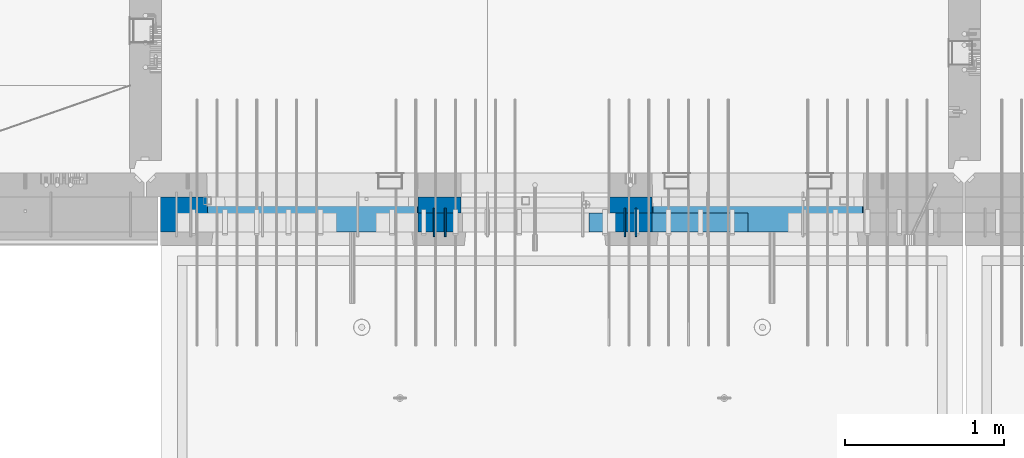
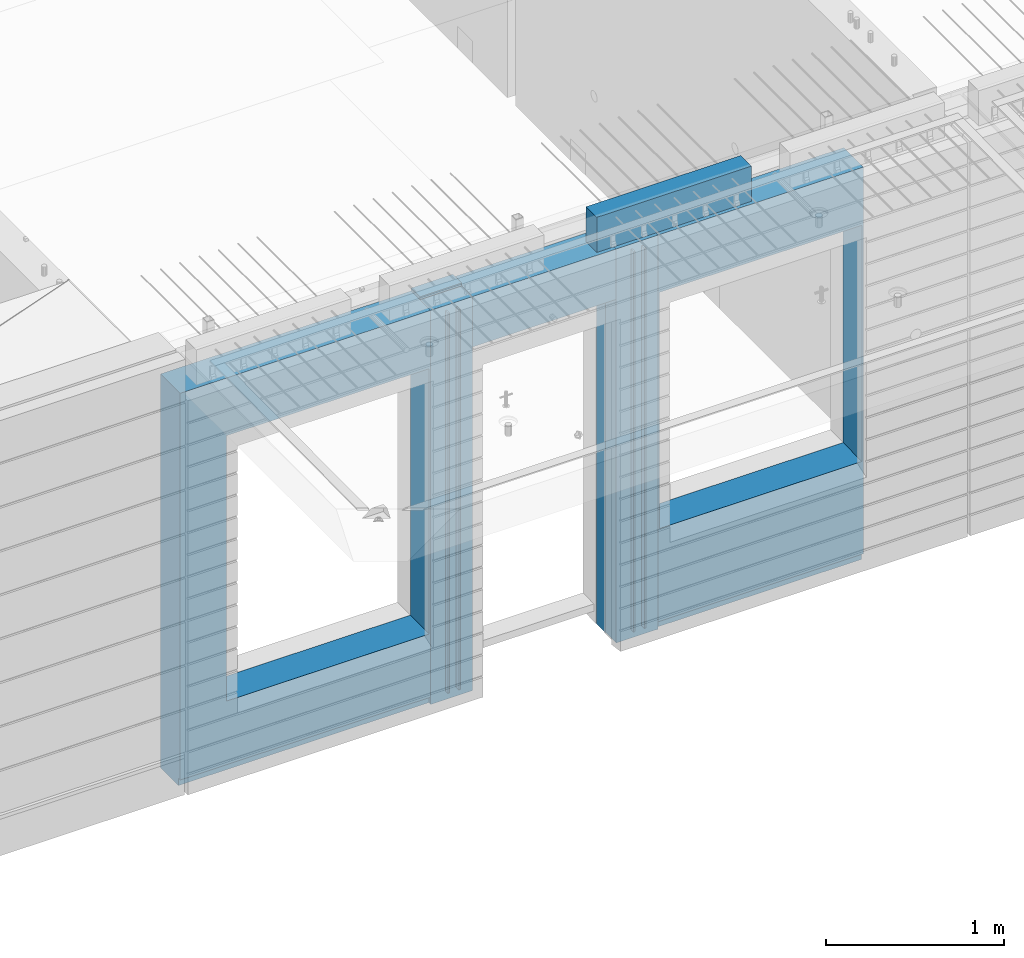
# One storey, part 230 of 350: 10 walls, 3 elements without a shape of their own.
"""IFC2X3 building model written with IfcOpenShell, lengths in millimetres."""

from ifc_helpers import new_model, si_unit, frame, origin_with_axes, place, context, subcontext, project, spatial, faceted_brep, material, type_object, element, aggregate, save


model = new_model("IFC2X3")

# Units and contexts
model_context = context("Model", 3, precision=1e-05, world=origin_with_axes())
body_context = subcontext(model_context, "Body", "Model", "MODEL_VIEW")
ifc_project = project(units=[si_unit("LENGTHUNIT", "METRE", prefix="MILLI"), si_unit("AREAUNIT", "SQUARE_METRE"), si_unit("VOLUMEUNIT", "CUBIC_METRE"), si_unit("MASSUNIT", "GRAM", prefix="KILO"), si_unit("TIMEUNIT", "SECOND"), si_unit("PLANEANGLEUNIT", "RADIAN"), si_unit("SOLIDANGLEUNIT", "STERADIAN"), si_unit("THERMODYNAMICTEMPERATUREUNIT", "DEGREE_CELSIUS"), si_unit("LUMINOUSINTENSITYUNIT", "LUMEN")], contexts=[model_context])

# Site, building, storey
site_placement = place(None, origin_with_axes())
site = spatial("IfcSite", under=ifc_project, at=site_placement, CompositionType="ELEMENT")
building_placement = place(site_placement, origin_with_axes())
building = spatial("IfcBuilding", under=site, at=building_placement, CompositionType="ELEMENT")
storey_placement = place(building_placement, origin_with_axes())
storey = spatial("IfcBuildingStorey", under=building, at=storey_placement, Name="2", CompositionType="ELEMENT", Elevation=0.0)

# Assembly, walls
assembly_1_placement = place(storey_placement, origin_with_axes())
assembly_1 = element("IfcElementAssembly", 1, at=assembly_1_placement, inside=storey, AssemblyPlace="NOTDEFINED", PredefinedType="REINFORCEMENT_UNIT")
ifc_material_1 = material(Name="Undefined")
wall_type_1 = type_object("IfcWallType", PredefinedType="NOTDEFINED")
wall_1_placement = place(assembly_1_placement, frame((18475.0, 7780.0, 86115.0), z_axis=(0.0, 0.0, 1.0), x_axis=(0.0, -1.0, 0.0)))
wall_1 = element("IfcWall", 2, at=wall_1_placement, type_object=wall_type_1, material=ifc_material_1, Name="(PD)", context=body_context, shape_type="Brep", body=[
    faceted_brep([(0.0, 5.0, -1300.0), (0.0, 5.0, 1300.0), (180.0, 5.0, 1300.0), (180.0, 5.0, -1300.0), (0.0, -5.0, 1300.0), (180.0, -5.0, 1300.0), (0.0, -5.0, -1300.0), (180.0, -5.0, -1300.0)], [[[0, 1, 2, 3]], [[1, 4, 5, 2]], [[4, 6, 7, 5]], [[6, 0, 3, 7]], [[5, 7, 3, 2]], [[6, 4, 1, 0]]]),
])
wall_2_placement = place(assembly_1_placement, frame((18545.0, 7780.0, 86115.0), z_axis=(0.0, 0.0, 1.0), x_axis=(0.0, -1.0, 0.0)))
wall_2 = element("IfcWall", 3, at=wall_2_placement, type_object=wall_type_1, material=ifc_material_1, Name="(PD)", context=body_context, shape_type="Brep", body=[
    faceted_brep([(0.0, 5.0, -1300.0), (0.0, 5.0, 1300.0), (180.0, 5.0, 1300.0), (180.0, 5.0, -1300.0), (0.0, -5.0, 1300.0), (180.0, -5.0, 1300.0), (0.0, -5.0, -1300.0), (180.0, -5.0, -1300.0)], [[[0, 1, 2, 3]], [[1, 4, 5, 2]], [[4, 6, 7, 5]], [[6, 0, 3, 7]], [[5, 7, 3, 2]], [[6, 4, 1, 0]]]),
])
wall_3_placement = place(assembly_1_placement, frame((19675.0, 7779.99999999997, 86115.0), z_axis=(0.0, 0.0, 1.0), x_axis=(0.0, -1.0, 0.0)))
wall_3 = element("IfcWall", 4, at=wall_3_placement, type_object=wall_type_1, material=ifc_material_1, Name="(PD)", context=body_context, shape_type="Brep", body=[
    faceted_brep([(0.0, 5.0, -1300.0), (0.0, 5.0, 1300.0), (180.0, 5.0, 1300.0), (180.0, 5.0, -1300.0), (0.0, -5.0, 1300.0), (180.0, -5.0, 1300.0), (0.0, -5.0, -1300.0), (180.0, -5.0, -1300.0)], [[[0, 1, 2, 3]], [[1, 4, 5, 2]], [[4, 6, 7, 5]], [[6, 0, 3, 7]], [[5, 7, 3, 2]], [[6, 4, 1, 0]]]),
])
wall_4_placement = place(assembly_1_placement, frame((19745.0, 7780.0, 86115.0), z_axis=(0.0, 0.0, 1.0), x_axis=(0.0, -1.0, 0.0)))
wall_4 = element("IfcWall", 5, at=wall_4_placement, type_object=wall_type_1, material=ifc_material_1, Name="(PD)", context=body_context, shape_type="Brep", body=[
    faceted_brep([(0.0, 5.0, -1300.0), (0.0, 5.0, 1300.0), (180.0, 5.0, 1300.0), (180.0, 5.0, -1300.0), (0.0, -5.0, 1300.0), (180.0, -5.0, 1300.0), (0.0, -5.0, -1300.0), (180.0, -5.0, -1300.0)], [[[0, 1, 2, 3]], [[1, 4, 5, 2]], [[4, 6, 7, 5]], [[6, 0, 3, 7]], [[5, 7, 3, 2]], [[6, 4, 1, 0]]]),
])

# Assemblies, wall
assembly_2_placement = place(storey_placement, origin_with_axes())
assembly_2 = element("IfcElementAssembly", 6, at=assembly_2_placement, inside=storey, AssemblyPlace="NOTDEFINED", PredefinedType="REINFORCEMENT_UNIT")
assembly_3_placement = place(assembly_2_placement, origin_with_axes())
assembly_3 = element("IfcElementAssembly", 7, at=assembly_3_placement, Name="Steel Assembly", AssemblyPlace="NOTDEFINED", PredefinedType="NOTDEFINED")
aggregate(assembly_2, [assembly_3])
ifc_material_2 = material()
wall_type_2 = type_object("IfcWallType", PredefinedType="NOTDEFINED")
wall_5_placement = place(assembly_3_placement, frame((19449.9998568133, 7690.00021946163, 87590.0), z_axis=(0.0, 0.0, 1.0), x_axis=(1.0, 0.0, 0.0)))
wall_5 = element("IfcWall", 8, at=wall_5_placement, type_object=wall_type_2, material=ifc_material_2, context=body_context, shape_type="Brep", body=[
    faceted_brep([(0.0, 60.0, -120.0), (0.0, 60.0, 120.0), (1000.0, 60.0, 120.0), (1000.0, 60.0, -120.0), (0.0, -60.0, 120.0), (1000.0, -60.0, 120.0), (0.0, -60.0, -120.0), (1000.0, -60.0, -120.0)], [[[0, 1, 2, 3]], [[1, 4, 5, 2]], [[4, 6, 7, 5]], [[6, 0, 3, 7]], [[5, 7, 3, 2]], [[6, 4, 1, 0]]]),
])
aggregate(assembly_3, [wall_5])

# Wall
ifc_material_3 = material(Name="CONCRETE/C35/45")
wall_type_3 = type_object("IfcWallType", PredefinedType="NOTDEFINED")
wall_6_placement = place(assembly_1_placement, frame((18645.0200381475, 7800.0, 86112.5), z_axis=(0.0, 0.0, 1.0), x_axis=(-1.0, 3.00000001838171e-08, 0.0)))
wall_6 = element("IfcWall", 9, at=wall_6_placement, type_object=wall_type_3, material=ifc_material_3, context=body_context, shape_type="Brep", body=[
    faceted_brep([(0.0, 50.0, -1357.5), (0.0, 50.0, 1357.5), (270.001908754726, 50.0, 1357.5), (270.001908754726, 50.0, -1357.5), (0.0, -50.0, 1357.5), (270.001908754726, -50.0, 1357.5), (0.0, -50.0, -1357.5), (270.001908754726, -50.0, -1357.5)], [[[0, 1, 2, 3]], [[1, 4, 5, 2]], [[4, 6, 7, 5]], [[6, 0, 3, 7]], [[5, 7, 3, 2]], [[6, 4, 1, 0]]]),
])

wall_7_placement = place(assembly_1_placement, frame((19845.0100381475, 7800.0, 86112.5), z_axis=(0.0, 0.0, 1.0), x_axis=(-1.0, 3.00000001838171e-08, 0.0)))
wall_7 = element("IfcWall", 10, at=wall_7_placement, type_object=wall_type_3, material=ifc_material_3, context=body_context, shape_type="Brep", body=[
    faceted_brep([(0.0, 50.0, -1357.5), (0.0, 50.0, 1357.5), (270.001908754726, 50.0, 1357.5), (270.001908754726, 50.0, -1357.5), (0.0, -50.0, 1357.5), (270.001908754726, -50.0, 1357.5), (0.0, -50.0, -1357.5), (270.001908754726, -50.0, -1357.5)], [[[0, 1, 2, 3]], [[1, 4, 5, 2]], [[4, 6, 7, 5]], [[6, 0, 3, 7]], [[5, 7, 3, 2]], [[6, 4, 1, 0]]]),
])

ifc_material_4 = material(Name="SPU")
wall_type_4 = type_object("IfcWallType", PredefinedType="NOTDEFINED")
wall_8_placement = place(assembly_1_placement, frame((18645.0100381475, 7690.0, 86102.5), z_axis=(0.0, 0.0, 1.0), x_axis=(-1.0, 3.00000001838171e-08, 0.0)))
wall_8 = element("IfcWall", 11, at=wall_8_placement, type_object=wall_type_4, material=ifc_material_4, context=body_context, shape_type="Brep", body=[
    faceted_brep([(0.0, 60.0, -1347.5), (0.0, 60.0, 1347.5), (270.001908754726, 60.0, 1347.5), (270.001908754726, 60.0, -1347.5), (0.0, -60.0, 1347.5), (270.001908754726, -60.0, 1347.5), (0.0, -60.0, -1347.5), (270.001908754726, -60.0, -1347.5)], [[[0, 1, 2, 3]], [[1, 4, 5, 2]], [[4, 6, 7, 5]], [[6, 0, 3, 7]], [[5, 7, 3, 2]], [[6, 4, 1, 0]]]),
])

wall_9_placement = place(assembly_1_placement, frame((19845.0100381475, 7690.0, 86102.5), z_axis=(0.0, 0.0, 1.0), x_axis=(-1.0, 3.00000001838171e-08, 0.0)))
wall_9 = element("IfcWall", 12, at=wall_9_placement, type_object=wall_type_4, material=ifc_material_4, context=body_context, shape_type="Brep", body=[
    faceted_brep([(0.0, 60.0, -1347.5), (0.0, 60.0, 1347.5), (270.001908754726, 60.0, 1347.5), (270.001908754726, 60.0, -1347.5), (0.0, -60.0, 1347.5), (270.001908754726, -60.0, 1347.5), (0.0, -60.0, -1347.5), (270.001908754726, -60.0, -1347.5)], [[[0, 1, 2, 3]], [[1, 4, 5, 2]], [[4, 6, 7, 5]], [[6, 0, 3, 7]], [[5, 7, 3, 2]], [[6, 4, 1, 0]]]),
])

ifc_material_5 = material(Name="COS5gt")
wall_type_5 = type_object("IfcWallType", PredefinedType="NOTDEFINED")
wall_10_placement = place(assembly_1_placement, frame((21175.0, 7740.0, 86102.5), z_axis=(0.0, 0.0, 1.0), x_axis=(-1.0, 3.00000001838171e-08, 0.0)))
wall_10 = element("IfcWall", 13, at=wall_10_placement, type_object=wall_type_5, material=ifc_material_5, context=body_context, shape_type="Brep", body=[
    faceted_brep([(1329.98996185248, -10.0, 1347.5), (1329.98996185248, -10.0, -1347.5), (1329.98996185248, 90.0, -1347.5), (1329.98996185248, 90.0, -1297.5), (1329.98996185248, 110.0, -1297.5), (1329.98996185248, 110.0, 1347.5), (0.0, 110.0, 1347.5), (0.0, -110.0, 1347.5), (1329.98996185248, -110.0, 1347.5), (0.0, -110.0, -1347.5), (0.0, 110.0, -1297.5), (0.0, 90.0, -1297.5), (0.0, 90.0, -1347.5), (1325.94608167329, -110.0, -668.445945945947), (1320.00013572734, 110.0, -662.5), (1290.00013572734, 110.0, -662.5), (40.0001357273395, 110.0, -662.5), (10.0001357273395, 110.0, -662.5), (4.05418978139278, -110.0, -668.445945945947), (1329.98996185248, -110.0, -1347.5), (4.05418978139278, -109.999999999999, 958.445945945947), (1325.94608167329, -109.999999999999, 958.445945945947), (1320.00013572734, 110.0, -657.5), (1320.00013572734, 110.0, 952.5), (10.0001357273395, 110.0, 952.5), (10.0001357273395, 110.0, -657.5), (1599.99187060721, -10.0, 1347.5), (1599.99187060721, 110.0, 1347.5), (1600.00051719707, 110.0, 1002.5), (1600.00051719707, -10.0, 1002.5), (2529.97996185248, -110.0, 1347.5), (2529.97996185248, -109.999999999999, 1002.5), (2529.97996185248, -10.0, 1002.5), (2529.97996185248, -10.0, 1347.5), (1599.99187060721, -110.0, 1347.5), (1600.00051719707, -109.999999999999, 1002.5), (2610.00051719707, 110.0, 1002.5), (2610.00051719707, -10.0, 1002.5), (2609.99996185247, 110.0, 992.5), (2609.99996185247, -10.0, 992.5), (4420.0, 110.0, -1297.5), (4420.0, 90.0, -1297.5), (2609.99996185247, 90.0, -1297.5), (2609.99996185247, 110.0, -1297.5), (4420.0, 110.0, 1347.5), (4420.0, -110.0, 1347.5), (4420.0, -110.0, -1347.5), (4420.0, 90.0, -1347.5), (2609.99996185247, 90.0, -1347.5), (2609.99996185247, -10.0, -1347.5), (2799.9818706072, -10.0, -1347.5), (2799.9818706072, -10.0, 1347.5), (2799.9818706072, -110.0, -1347.5), (2799.9818706072, -110.0, 1347.5), (4125.94531873383, -110.0, -868.445945945947), (4119.99937278789, 110.0, -862.5), (4089.99937278789, 110.0, -862.5), (2839.99937278789, 110.0, -862.5), (2809.99937278789, 110.0, -862.5), (2804.05342684194, -110.0, -868.445945945947), (2804.05342684194, -109.999999999999, 958.445945945947), (4125.94531873383, -109.999999999999, 958.445945945947), (4119.99937278789, 110.0, -857.5), (4119.99937278789, 110.0, 952.5), (2809.99937278789, 110.0, 952.5), (2809.99937278789, 110.0, -857.5)], [[[0, 1, 2, 3, 4, 5]], [[6, 7, 8, 0, 5]], [[9, 7, 6, 10, 11, 12]], [[13, 14, 15, 16, 17, 18]], [[7, 9, 19, 8], [13, 18, 20, 21]], [[22, 14, 13, 21, 23]], [[20, 24, 23, 21]], [[18, 17, 25, 24, 20]], [[10, 6, 5, 4], [17, 16, 15, 14, 22, 23, 24, 25]], [[11, 10, 4, 3]], [[12, 11, 3, 2]], [[19, 9, 12, 2, 1]], [[8, 19, 1, 0]], [[26, 27, 28, 29]], [[30, 31, 32, 33]], [[34, 35, 31, 30]], [[35, 34, 26, 29]], [[36, 37, 32, 31, 35, 29, 28]], [[36, 38, 39, 37]], [[40, 41, 42, 43]], [[44, 45, 46, 47, 41, 40]], [[41, 47, 48, 42]], [[38, 43, 42, 48, 49, 39]], [[33, 32, 37, 39, 49, 50, 51]], [[48, 47, 46, 52, 50, 49]], [[53, 51, 50, 52]], [[54, 55, 56, 57, 58, 59]], [[46, 45, 53, 52], [54, 59, 60, 61]], [[62, 55, 54, 61, 63]], [[60, 64, 63, 61]], [[59, 58, 65, 64, 60]], [[44, 40, 43, 38, 36, 28, 27], [58, 57, 56, 55, 62, 63, 64, 65]], [[34, 30, 33, 51, 53, 45, 44, 27, 26]]]),
])

aggregate(assembly_1, [wall_6, wall_8, wall_9, wall_1, wall_2, wall_7, wall_3, wall_4, wall_10])

save(model, "model.ifc")
